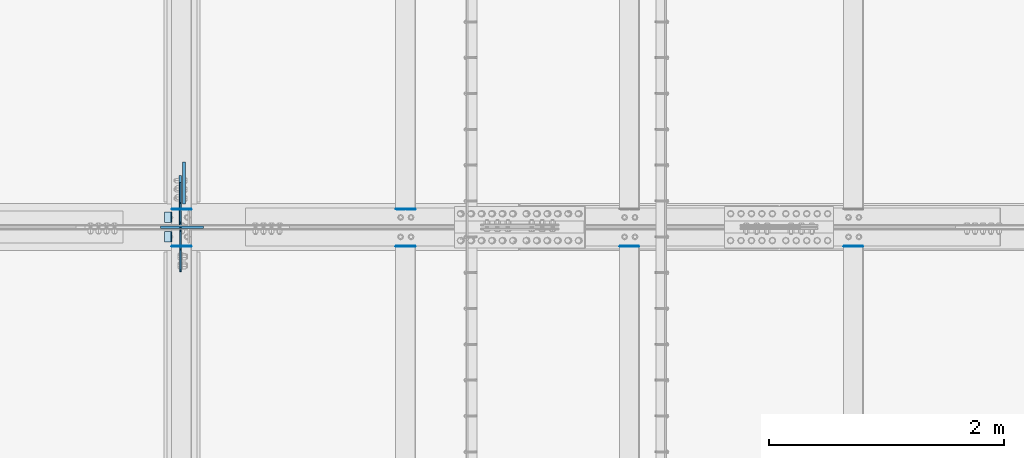
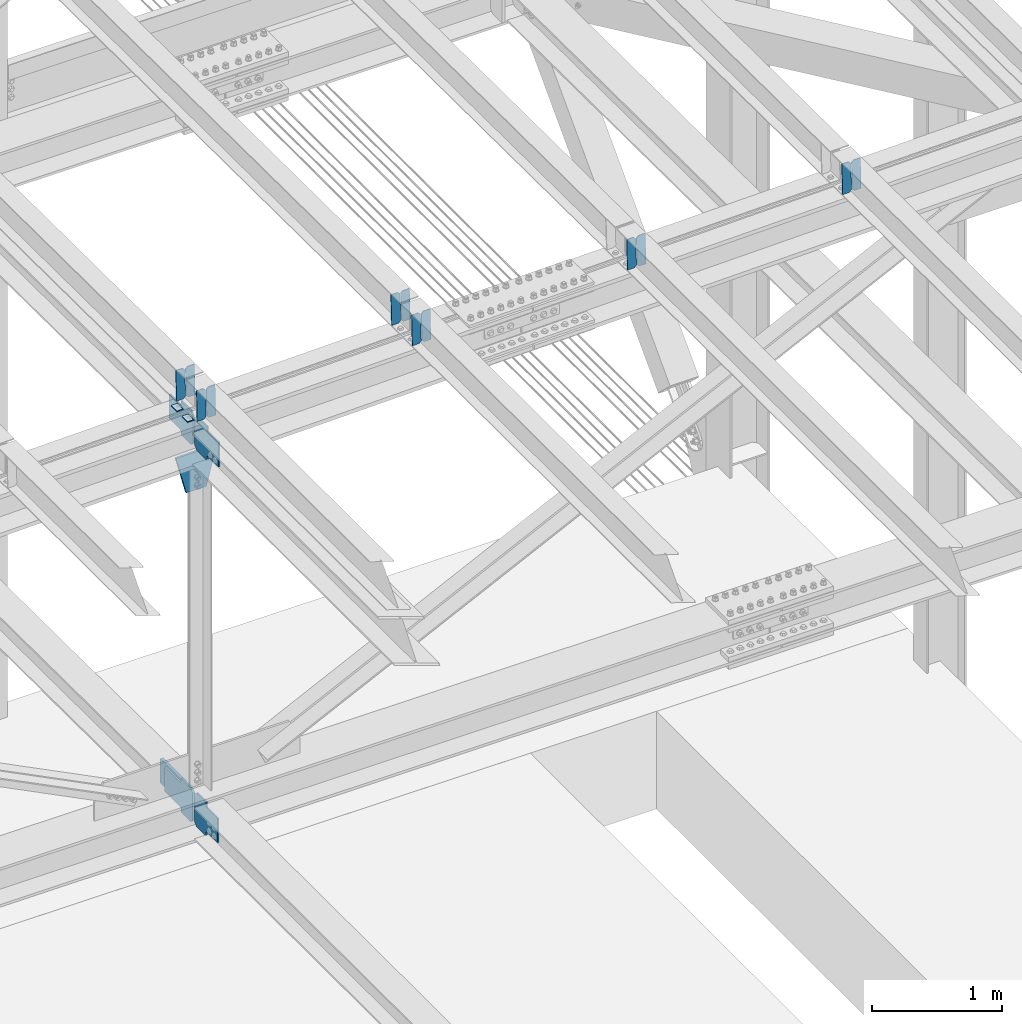
# One storey, part 3448 of 3843: 20 plates, 9 elements without a shape of their own.
"""IFC2X3 building model written with IfcOpenShell, lengths in millimetres."""

from ifc_helpers import new_model, si_unit, frame, origin_with_axes, place, context, subcontext, project, spatial, faceted_brep, material, type_object, element, aggregate, save


model = new_model("IFC2X3")

# Units and contexts
model_context = context("Model", 3, precision=1e-05, world=origin_with_axes())
body_context = subcontext(model_context, "Body", "Model", "MODEL_VIEW")
ifc_project = project(units=[si_unit("LENGTHUNIT", "METRE", prefix="MILLI"), si_unit("AREAUNIT", "SQUARE_METRE"), si_unit("VOLUMEUNIT", "CUBIC_METRE"), si_unit("MASSUNIT", "GRAM", prefix="KILO"), si_unit("TIMEUNIT", "SECOND"), si_unit("PLANEANGLEUNIT", "RADIAN"), si_unit("SOLIDANGLEUNIT", "STERADIAN"), si_unit("THERMODYNAMICTEMPERATUREUNIT", "DEGREE_CELSIUS"), si_unit("LUMINOUSINTENSITYUNIT", "LUMEN")], contexts=[model_context])

# Site, building, storey
site_placement = place(None, origin_with_axes())
site = spatial("IfcSite", under=ifc_project, at=site_placement, CompositionType="ELEMENT")
building_placement = place(site_placement, origin_with_axes())
building = spatial("IfcBuilding", under=site, at=building_placement, Name="Undefined", CompositionType="ELEMENT")
storey_placement = place(building_placement, origin_with_axes())
storey = spatial("IfcBuildingStorey", under=building, at=storey_placement, Name="Undefined", CompositionType="ELEMENT", Elevation=0.0)

# Assembly, plates
assembly_1_placement = place(storey_placement, origin_with_axes())
assembly_1 = element("IfcElementAssembly", 1, at=assembly_1_placement, inside=storey, Name="BEAM", AssemblyPlace="NOTDEFINED", PredefinedType="RIGID_FRAME")
ifc_material = material(Name="STEEL/A572-50")
plate_type_1 = type_object("IfcPlateType", PredefinedType="NOTDEFINED")
plate_1_placement = place(assembly_1_placement, frame((62718.6964783427, 75781.7002512663, 46060.2152839954), z_axis=(-0.0211520980825589, 0.00792817899846704, 0.999744833807344), x_axis=(-0.99977626934565, -0.00016773499999526, -0.021151433007337)))
plate_1 = element("IfcPlate", 2, at=plate_1_placement, type_object=plate_type_1, material=ifc_material, Name="PLATE", context=body_context, shape_type="Brep", body=[
    faceted_brep([(0.0, -3.17499999999927, 0.0), (6.83940015733242e-10, -3.17499999996653, 288.924999998613), (6.54836185276508e-10, 3.17500000001746, 288.924999998591), (0.0, 3.17499999999927, 0.0), (60.3250007643655, -3.17500000017753, 288.924999998606), (60.3250007643219, 3.17499999979918, 288.924999998584), (79.3750000013097, -3.17500000025029, 269.875000761494), (79.375000001266, 3.17499999972642, 269.875000761487), (79.375000000713, -3.17500000026484, 19.0499992370605), (79.3750000006985, 3.17499999971187, 19.0499992370533), (60.325000763667, -3.17500000020664, -1.45519152283669e-11), (60.3250007636234, 3.17499999977736, -3.63797880709171e-11)], [[[0, 1, 2, 3]], [[1, 4, 5, 2]], [[4, 6, 7, 5]], [[6, 8, 9, 7]], [[8, 10, 11, 9]], [[10, 0, 3, 11]], [[5, 7, 9, 11, 3, 2]], [[10, 8, 6, 4, 1, 0]]]),
])
plate_2_placement = place(assembly_1_placement, frame((62632.9906576531, 75781.6858721703, 46058.4020774081), z_axis=(-0.0211520980825589, 0.00792817899846704, 0.999744833807344), x_axis=(-0.99977626934565, -0.00016773499999526, -0.021151433007337)))
plate_2 = element("IfcPlate", 3, at=plate_2_placement, type_object=plate_type_1, material=ifc_material, Name="PLATE", context=body_context, shape_type="Brep", body=[
    faceted_brep([(4.36557456851006e-11, -3.17499999998836, 19.0499992370969), (6.11180439591408e-10, -3.17499999996653, 269.875000761516), (5.96628524363041e-10, 3.17500000001746, 269.875000761502), (1.45519152283669e-11, 3.17499999998836, 19.0499992370824), (19.0499992376572, -3.17500000003201, 288.924999998606), (19.0499992376281, 3.1749999999447, 288.924999998584), (79.3750000013242, -3.17500000025029, 288.924999998591), (79.3750000013097, 3.1749999997337, 288.92499999857), (79.3750000006548, -3.17500000026484, -2.18278728425503e-11), (79.3750000006403, 3.17499999969732, -2.91038304567337e-11), (19.0499992370023, -3.17500000005384, 0.0), (19.0499992369587, 3.17499999992287, -1.45519152283669e-11)], [[[0, 1, 2, 3]], [[1, 4, 5, 2]], [[4, 6, 7, 5]], [[6, 8, 9, 7]], [[8, 10, 11, 9]], [[10, 0, 3, 11]], [[5, 7, 9, 11, 3, 2]], [[10, 8, 6, 4, 1, 0]]]),
])

assembly_2_placement = place(storey_placement, origin_with_axes())
assembly_2 = element("IfcElementAssembly", 4, at=assembly_2_placement, inside=storey, Name="BEAM", AssemblyPlace="NOTDEFINED", PredefinedType="RIGID_FRAME")
plate_3_placement = place(assembly_2_placement, frame((62718.6964783481, 75466.0175545333, 46061.7338311287), z_axis=(-0.0211520980329588, 0.00187065200053622, 0.999774519284172), x_axis=(-0.999776269352655, -3.88860000349027e-05, -0.021152062007432)))
plate_3 = element("IfcPlate", 5, at=plate_3_placement, type_object=plate_type_1, material=ifc_material, Name="PLATE", context=body_context, shape_type="Brep", body=[
    faceted_brep([(0.0, -3.17499999999927, 0.0), (6.83940015733242e-10, -3.17499999996653, 288.924999998613), (6.54836185276508e-10, 3.17500000001746, 288.924999998591), (0.0, 3.17499999999927, 0.0), (60.3250007643655, -3.17500000017753, 288.924999998606), (60.3250007643219, 3.17499999979918, 288.924999998584), (79.3750000013097, -3.17500000025029, 269.875000761494), (79.375000001266, 3.17499999972642, 269.875000761487), (79.375000000713, -3.17500000026484, 19.0499992370605), (79.3750000006985, 3.17499999971187, 19.0499992370533), (60.325000763667, -3.17500000020664, -1.45519152283669e-11), (60.3250007636234, 3.17499999977736, -3.63797880709171e-11)], [[[0, 1, 2, 3]], [[1, 4, 5, 2]], [[4, 6, 7, 5]], [[6, 8, 9, 7]], [[8, 10, 11, 9]], [[10, 0, 3, 11]], [[5, 7, 9, 11, 3, 2]], [[10, 8, 6, 4, 1, 0]]]),
])
plate_4_placement = place(assembly_2_placement, frame((62632.9906576585, 75466.0141617909, 46059.9205707012), z_axis=(-0.0211520980329588, 0.00187065200053622, 0.999774519284172), x_axis=(-0.999776269352655, -3.88860000349027e-05, -0.021152062007432)))
plate_4 = element("IfcPlate", 6, at=plate_4_placement, type_object=plate_type_1, material=ifc_material, Name="PLATE", context=body_context, shape_type="Brep", body=[
    faceted_brep([(4.36557456851006e-11, -3.17499999998836, 19.0499992370969), (6.11180439591408e-10, -3.17499999996653, 269.875000761516), (5.96628524363041e-10, 3.17500000001746, 269.875000761502), (1.45519152283669e-11, 3.17499999998836, 19.0499992370824), (19.0499992376572, -3.17500000003201, 288.924999998606), (19.0499992376281, 3.1749999999447, 288.924999998584), (79.3750000013242, -3.17500000025029, 288.924999998591), (79.3750000013097, 3.1749999997337, 288.92499999857), (79.3750000006548, -3.17500000026484, -2.18278728425503e-11), (79.3750000006403, 3.17499999969732, -2.91038304567337e-11), (19.0499992370023, -3.17500000005384, 0.0), (19.0499992369587, 3.17499999992287, -1.45519152283669e-11)], [[[0, 1, 2, 3]], [[1, 4, 5, 2]], [[4, 6, 7, 5]], [[6, 8, 9, 7]], [[8, 10, 11, 9]], [[10, 0, 3, 11]], [[5, 7, 9, 11, 3, 2]], [[10, 8, 6, 4, 1, 0]]]),
])

assembly_3_placement = place(storey_placement, origin_with_axes())
assembly_3 = element("IfcElementAssembly", 7, at=assembly_3_placement, inside=storey, Name="BEAM", AssemblyPlace="NOTDEFINED", PredefinedType="RIGID_FRAME")
plate_5_placement = place(assembly_3_placement, frame((68433.6967113588, 75465.963914704, 46184.59069618), z_axis=(-0.0211520984965173, 0.00205084399976477, 0.999774165883517), x_axis=(-0.999776269341419, -4.278700010456e-05, -0.0211520550071887)))
plate_5 = element("IfcPlate", 8, at=plate_5_placement, type_object=plate_type_1, material=ifc_material, Name="PLATE", context=body_context, shape_type="Brep", body=[
    faceted_brep([(0.0, -3.17499999999927, 0.0), (6.83940015733242e-10, -3.17499999996653, 288.924999998613), (6.54836185276508e-10, 3.17500000001746, 288.924999998591), (0.0, 3.17499999999927, 0.0), (60.3250007643655, -3.17500000017753, 288.924999998606), (60.3250007643219, 3.17499999979918, 288.924999998584), (79.3750000013097, -3.17500000025029, 269.875000761494), (79.375000001266, 3.17499999972642, 269.875000761487), (79.375000000713, -3.17500000026484, 19.0499992370605), (79.3750000006985, 3.17499999971187, 19.0499992370533), (60.325000763667, -3.17500000020664, -1.45519152283669e-11), (60.3250007636234, 3.17499999977736, -3.63797880709171e-11)], [[[0, 1, 2, 3]], [[1, 4, 5, 2]], [[4, 6, 7, 5]], [[6, 8, 9, 7]], [[8, 10, 11, 9]], [[10, 0, 3, 11]], [[5, 7, 9, 11, 3, 2]], [[10, 8, 6, 4, 1, 0]]]),
])
plate_6_placement = place(assembly_3_placement, frame((68347.9908906676, 75465.9601956653, 46182.7774363933), z_axis=(-0.0211520984965173, 0.00205084399976477, 0.999774165883517), x_axis=(-0.999776269341419, -4.278700010456e-05, -0.0211520550071887)))
plate_6 = element("IfcPlate", 9, at=plate_6_placement, type_object=plate_type_1, material=ifc_material, Name="PLATE", context=body_context, shape_type="Brep", body=[
    faceted_brep([(4.36557456851006e-11, -3.17499999998836, 19.0499992370969), (6.11180439591408e-10, -3.17499999996653, 269.875000761516), (5.96628524363041e-10, 3.17500000001746, 269.875000761502), (1.45519152283669e-11, 3.17499999998836, 19.0499992370824), (19.0499992376572, -3.17500000003201, 288.924999998606), (19.0499992376281, 3.1749999999447, 288.924999998584), (79.3750000013242, -3.17500000025029, 288.924999998591), (79.3750000013097, 3.1749999997337, 288.92499999857), (79.3750000006548, -3.17500000026484, -2.18278728425503e-11), (79.3750000006403, 3.17499999969732, -2.91038304567337e-11), (19.0499992370023, -3.17500000005384, 0.0), (19.0499992369587, 3.17499999992287, -1.45519152283669e-11)], [[[0, 1, 2, 3]], [[1, 4, 5, 2]], [[4, 6, 7, 5]], [[6, 8, 9, 7]], [[8, 10, 11, 9]], [[10, 0, 3, 11]], [[5, 7, 9, 11, 3, 2]], [[10, 8, 6, 4, 1, 0]]]),
])
aggregate(assembly_3, [plate_5, plate_6])

assembly_4_placement = place(storey_placement, origin_with_axes())
assembly_4 = element("IfcElementAssembly", 10, at=assembly_4_placement, inside=storey, Name="BEAM", AssemblyPlace="NOTDEFINED", PredefinedType="RIGID_FRAME")
plate_7_placement = place(assembly_4_placement, frame((66528.6964818659, 75465.9760177746, 46144.1746497953), z_axis=(-0.0211520978066692, 0.00201018800094608, 0.999774248469412), x_axis=(-0.999776269341419, -4.278700010456e-05, -0.0211520550071887)))
plate_7 = element("IfcPlate", 11, at=plate_7_placement, type_object=plate_type_1, material=ifc_material, Name="PLATE", context=body_context, shape_type="Brep", body=[
    faceted_brep([(0.0, -3.17499999999927, 0.0), (6.83940015733242e-10, -3.17499999996653, 288.924999998613), (6.54836185276508e-10, 3.17500000001746, 288.924999998591), (0.0, 3.17499999999927, 0.0), (60.3250007643655, -3.17500000017753, 288.924999998606), (60.3250007643219, 3.17499999979918, 288.924999998584), (79.3750000013097, -3.17500000025029, 269.875000761494), (79.375000001266, 3.17499999972642, 269.875000761487), (79.375000000713, -3.17500000026484, 19.0499992370605), (79.3750000006985, 3.17499999971187, 19.0499992370533), (60.325000763667, -3.17500000020664, -1.45519152283669e-11), (60.3250007636234, 3.17499999977736, -3.63797880709171e-11)], [[[0, 1, 2, 3]], [[1, 4, 5, 2]], [[4, 6, 7, 5]], [[6, 8, 9, 7]], [[8, 10, 11, 9]], [[10, 0, 3, 11]], [[5, 7, 9, 11, 3, 2]], [[10, 8, 6, 4, 1, 0]]]),
])
plate_8_placement = place(assembly_4_placement, frame((66442.9906611746, 75465.9723700711, 46142.3613898619), z_axis=(-0.0211520978066692, 0.00201018800094608, 0.999774248469412), x_axis=(-0.999776269341419, -4.278700010456e-05, -0.0211520550071887)))
plate_8 = element("IfcPlate", 12, at=plate_8_placement, type_object=plate_type_1, material=ifc_material, Name="PLATE", context=body_context, shape_type="Brep", body=[
    faceted_brep([(4.36557456851006e-11, -3.17499999998836, 19.0499992370969), (6.11180439591408e-10, -3.17499999996653, 269.875000761516), (5.96628524363041e-10, 3.17500000001746, 269.875000761502), (1.45519152283669e-11, 3.17499999998836, 19.0499992370824), (19.0499992376572, -3.17500000003201, 288.924999998606), (19.0499992376281, 3.1749999999447, 288.924999998584), (79.3750000013242, -3.17500000025029, 288.924999998591), (79.3750000013097, 3.1749999997337, 288.92499999857), (79.3750000006548, -3.17500000026484, -2.18278728425503e-11), (79.3750000006403, 3.17499999969732, -2.91038304567337e-11), (19.0499992370023, -3.17500000005384, 0.0), (19.0499992369587, 3.17499999992287, -1.45519152283669e-11)], [[[0, 1, 2, 3]], [[1, 4, 5, 2]], [[4, 6, 7, 5]], [[6, 8, 9, 7]], [[8, 10, 11, 9]], [[10, 0, 3, 11]], [[5, 7, 9, 11, 3, 2]], [[10, 8, 6, 4, 1, 0]]]),
])
aggregate(assembly_4, [plate_7, plate_8])

assembly_5_placement = place(storey_placement, origin_with_axes())
assembly_5 = element("IfcElementAssembly", 13, at=assembly_5_placement, inside=storey, Name="BEAM", AssemblyPlace="NOTDEFINED", PredefinedType="RIGID_FRAME")
plate_9_placement = place(assembly_5_placement, frame((64623.6967069092, 75781.6879853969, 46101.7727157053), z_axis=(-0.0211520981591165, 0.00796893299830843, 0.999744509787543), x_axis=(-0.99977626934565, -0.00016773499999526, -0.021151433007337)))
plate_9 = element("IfcPlate", 14, at=plate_9_placement, type_object=plate_type_1, material=ifc_material, Name="PLATE", context=body_context, shape_type="Brep", body=[
    faceted_brep([(0.0, -3.17499999999927, 0.0), (6.83940015733242e-10, -3.17499999996653, 288.924999998613), (6.54836185276508e-10, 3.17500000001746, 288.924999998591), (0.0, 3.17499999999927, 0.0), (60.3250007643655, -3.17500000017753, 288.924999998606), (60.3250007643219, 3.17499999979918, 288.924999998584), (79.3750000013097, -3.17500000025029, 269.875000761494), (79.375000001266, 3.17499999972642, 269.875000761487), (79.375000000713, -3.17500000026484, 19.0499992370605), (79.3750000006985, 3.17499999971187, 19.0499992370533), (60.325000763667, -3.17500000020664, -1.45519152283669e-11), (60.3250007636234, 3.17499999977736, -3.63797880709171e-11)], [[[0, 1, 2, 3]], [[1, 4, 5, 2]], [[4, 6, 7, 5]], [[6, 8, 9, 7]], [[8, 10, 11, 9]], [[10, 0, 3, 11]], [[5, 7, 9, 11, 3, 2]], [[10, 8, 6, 4, 1, 0]]]),
])
plate_10_placement = place(assembly_5_placement, frame((64537.9908862199, 75781.6735299861, 46099.9595097248), z_axis=(-0.0211520981591165, 0.00796893299830843, 0.999744509787543), x_axis=(-0.99977626934565, -0.00016773499999526, -0.021151433007337)))
plate_10 = element("IfcPlate", 15, at=plate_10_placement, type_object=plate_type_1, material=ifc_material, Name="PLATE", context=body_context, shape_type="Brep", body=[
    faceted_brep([(4.36557456851006e-11, -3.17499999998836, 19.0499992370969), (6.11180439591408e-10, -3.17499999996653, 269.875000761516), (5.96628524363041e-10, 3.17500000001746, 269.875000761502), (1.45519152283669e-11, 3.17499999998836, 19.0499992370824), (19.0499992376572, -3.17500000003201, 288.924999998606), (19.0499992376281, 3.1749999999447, 288.924999998584), (79.3750000013242, -3.17500000025029, 288.924999998591), (79.3750000013097, 3.1749999997337, 288.92499999857), (79.3750000006548, -3.17500000026484, -2.18278728425503e-11), (79.3750000006403, 3.17499999969732, -2.91038304567337e-11), (19.0499992370023, -3.17500000005384, 0.0), (19.0499992369587, 3.17499999992287, -1.45519152283669e-11)], [[[0, 1, 2, 3]], [[1, 4, 5, 2]], [[4, 6, 7, 5]], [[6, 8, 9, 7]], [[8, 10, 11, 9]], [[10, 0, 3, 11]], [[5, 7, 9, 11, 3, 2]], [[10, 8, 6, 4, 1, 0]]]),
])
aggregate(assembly_5, [plate_9, plate_10])

assembly_6_placement = place(storey_placement, origin_with_axes())
assembly_6 = element("IfcElementAssembly", 16, at=assembly_6_placement, inside=storey, Name="BEAM", AssemblyPlace="NOTDEFINED", PredefinedType="RIGID_FRAME")
plate_11_placement = place(assembly_6_placement, frame((64623.6967112793, 75465.99690233, 46103.3087150513), z_axis=(-0.0211520978190965, 0.00194001800016849, 0.999774387093413), x_axis=(-0.999776269338344, -4.08370000134752e-05, -0.0211520590071558)))
plate_11 = element("IfcPlate", 17, at=plate_11_placement, type_object=plate_type_1, material=ifc_material, Name="PLATE", context=body_context, shape_type="Brep", body=[
    faceted_brep([(0.0, -3.17499999999927, 0.0), (6.83940015733242e-10, -3.17499999996653, 288.924999998613), (6.54836185276508e-10, 3.17500000001746, 288.924999998591), (0.0, 3.17499999999927, 0.0), (60.3250007643655, -3.17500000017753, 288.924999998606), (60.3250007643219, 3.17499999979918, 288.924999998584), (79.3750000013097, -3.17500000025029, 269.875000761494), (79.375000001266, 3.17499999972642, 269.875000761487), (79.375000000713, -3.17500000026484, 19.0499992370605), (79.3750000006985, 3.17499999971187, 19.0499992370533), (60.325000763667, -3.17500000020664, -1.45519152283669e-11), (60.3250007636234, 3.17499999977736, -3.63797880709171e-11)], [[[0, 1, 2, 3]], [[1, 4, 5, 2]], [[4, 6, 7, 5]], [[6, 8, 9, 7]], [[8, 10, 11, 9]], [[10, 0, 3, 11]], [[5, 7, 9, 11, 3, 2]], [[10, 8, 6, 4, 1, 0]]]),
])
plate_12_placement = place(assembly_6_placement, frame((64537.9908905899, 75465.9933842938, 46101.4954548632), z_axis=(-0.0211520978190965, 0.00194001800016849, 0.999774387093413), x_axis=(-0.999776269338344, -4.08370000134752e-05, -0.0211520590071558)))
plate_12 = element("IfcPlate", 18, at=plate_12_placement, type_object=plate_type_1, material=ifc_material, Name="PLATE", context=body_context, shape_type="Brep", body=[
    faceted_brep([(4.36557456851006e-11, -3.17499999998836, 19.0499992370969), (6.11180439591408e-10, -3.17499999996653, 269.875000761516), (5.96628524363041e-10, 3.17500000001746, 269.875000761502), (1.45519152283669e-11, 3.17499999998836, 19.0499992370824), (19.0499992376572, -3.17500000003201, 288.924999998606), (19.0499992376281, 3.1749999999447, 288.924999998584), (79.3750000013242, -3.17500000025029, 288.924999998591), (79.3750000013097, 3.1749999997337, 288.92499999857), (79.3750000006548, -3.17500000026484, -2.18278728425503e-11), (79.3750000006403, 3.17499999969732, -2.91038304567337e-11), (19.0499992370023, -3.17500000005384, 0.0), (19.0499992369587, 3.17499999992287, -1.45519152283669e-11)], [[[0, 1, 2, 3]], [[1, 4, 5, 2]], [[4, 6, 7, 5]], [[6, 8, 9, 7]], [[8, 10, 11, 9]], [[10, 0, 3, 11]], [[5, 7, 9, 11, 3, 2]], [[10, 8, 6, 4, 1, 0]]]),
])
aggregate(assembly_6, [plate_11, plate_12])

# Plate
plate_type_2 = type_object("IfcPlateType", PredefinedType="NOTDEFINED")
plate_13_placement = place(assembly_1_placement, frame((62553.7676306388, 75755.5, 46051.5939415684), z_axis=(0.0, -1.0, 0.0), x_axis=(-0.999776270257024, 0.0, -0.0211520550054595)))
plate_13 = element("IfcPlate", 19, at=plate_13_placement, type_object=plate_type_2, material=ifc_material, Name="PLATE", context=body_context, shape_type="Brep", body=[
    faceted_brep([(9.52499999982683, -4.7625000001135, 88.8999999999942), (0.0, 4.76249999999709, 88.9000015258789), (0.0, 4.76249999999709, 0.0), (9.52499999981956, -4.76249999999709, 0.0), (63.4999984608512, -4.76249999988795, 88.8999999999796), (63.4999984608367, -4.76249999988795, -1.45519152283669e-11), (63.4999984608221, 4.76250000013533, -1.45519152283669e-11), (63.4999984608367, 4.76250000013533, 88.8999999999796)], [[[0, 1, 2, 3]], [[4, 5, 6, 7]], [[5, 4, 0, 3]], [[6, 5, 3, 2]], [[7, 6, 2, 1]], [[4, 7, 1, 0]]]),
])

aggregate(assembly_1, [plate_1, plate_2, plate_13])

plate_14_placement = place(assembly_2_placement, frame((62553.7676306388, 75590.4000015258, 46051.5939415684), z_axis=(0.0, -1.0, 0.0), x_axis=(-0.999776270257024, 0.0, -0.0211520550054595)))
plate_14 = element("IfcPlate", 20, at=plate_14_placement, type_object=plate_type_2, material=ifc_material, Name="PLATE", context=body_context, shape_type="Brep", body=[
    faceted_brep([(9.52499999982683, -4.7625000001135, 88.8999999999942), (0.0, 4.76249999999709, 88.9000015258789), (0.0, 4.76249999999709, 0.0), (9.52499999981956, -4.76249999999709, 0.0), (63.4999984608512, -4.76249999988795, 88.8999999999796), (63.4999984608367, -4.76249999988795, -1.45519152283669e-11), (63.4999984608221, 4.76250000013533, -1.45519152283669e-11), (63.4999984608367, 4.76250000013533, 88.8999999999796)], [[[0, 1, 2, 3]], [[4, 5, 6, 7]], [[5, 4, 0, 3]], [[6, 5, 3, 2]], [[7, 6, 2, 1]], [[4, 7, 1, 0]]]),
])

aggregate(assembly_2, [plate_3, plate_4, plate_14])

# Assembly, plate
assembly_7_placement = place(storey_placement, origin_with_axes())
assembly_7 = element("IfcElementAssembly", 21, at=assembly_7_placement, inside=storey, Name="BEAM", AssemblyPlace="NOTDEFINED", PredefinedType="RIGID_FRAME")
plate_type_3 = type_object("IfcPlateType", PredefinedType="NOTDEFINED")
plate_15_placement = place(assembly_7_placement, frame((62625.2874999051, 75621.3562499733, 42198.3670469889), z_axis=(0.0, -0.707106781186682, 0.707106781186413), x_axis=(0.0, -0.707106781186548, -0.707106781186548)))
plate_15 = element("IfcPlate", 22, at=plate_15_placement, type_object=plate_type_3, material=ifc_material, Name="PLATE", context=body_context, shape_type="Brep", body=[
    faceted_brep([(0.0, -6.3499999046162, 0.0), (-179.597849441064, -6.34999999999854, 179.597849441059), (-179.597849441064, 6.34999999999854, 179.597849441059), (7.27595761418343e-12, 6.3499999046162, 0.0), (-179.597849441061, -6.34999999999854, 224.499130046192), (-179.597849441061, 6.34999999999854, 224.499130046192), (-75.7636380416931, -6.34999999999854, 328.333341445563), (-75.7636380416931, 6.34999999999854, 328.333341445563), (-53.6447545305273, -6.34999999999854, 306.214457898401), (-53.6447545305273, 6.34999999999854, 306.214457898401), (-49.5245780623809, -6.34999999999854, 303.461443997949), (-49.5245780623809, 6.34999999999854, 303.461443997949), (-44.6644985443563, -6.34999999999854, 302.494714075376), (-44.6644985443563, 6.34999999999854, 302.494714075376), (-39.8044190263026, -6.34999999999854, 303.461443997981), (-39.8044190263026, 6.34999999999854, 303.461443997981), (-35.6842425581272, -6.34999999999854, 306.214457898459), (-35.6842425581272, 6.34999999999854, 306.214457898459), (81.0590871709428, -6.34999999999854, 422.957787626525), (81.0590871709428, 6.34999999999854, 422.957787626525), (242.703697350371, -6.34999999999854, 261.313177447377), (242.703697350371, 6.34999999999854, 261.313177447377), (125.960367621417, -6.34999999999854, 144.569847719406), (125.960367621417, 6.34999999999854, 144.569847719406), (123.207353720878, -6.34999999999854, 140.449671251223), (123.207353720878, 6.34999999999854, 140.449671251223), (122.24062379825, -6.34999999999854, 135.58959173314), (122.24062379825, 6.34999999999854, 135.58959173314), (123.20735372082, -6.34999999999854, 130.729512215075), (123.20735372082, 6.34999999999854, 130.729512215075), (125.960367621301, -6.34999999999854, 126.609335746911), (125.960367621301, 6.34999999999854, 126.609335746911), (148.735492004496, -6.35000000000582, 103.834211399357), (148.735492004496, 6.35000000000582, 103.834211399357), (44.9012806051323, -6.35000000000582, -1.45519152283669e-11), (44.9012806051323, 6.35000000000582, -1.45519152283669e-11)], [[[0, 1, 2, 3]], [[1, 4, 5, 2]], [[4, 6, 7, 5]], [[6, 8, 9, 7]], [[8, 10, 11, 9]], [[10, 12, 13, 11]], [[12, 14, 15, 13]], [[14, 16, 17, 15]], [[16, 18, 19, 17]], [[18, 20, 21, 19]], [[20, 22, 23, 21]], [[22, 24, 25, 23]], [[24, 26, 27, 25]], [[26, 28, 29, 27]], [[28, 30, 31, 29]], [[30, 32, 33, 31]], [[32, 34, 35, 33]], [[34, 0, 3, 35]], [[5, 7, 9, 11, 13, 15, 17, 19, 21, 23, 25, 27, 29, 31, 33, 35, 3, 2]], [[34, 32, 30, 28, 26, 24, 22, 20, 18, 16, 14, 12, 10, 8, 6, 4, 1, 0]]]),
])

# Assembly, plates
assembly_8_placement = place(storey_placement, origin_with_axes())
assembly_8 = element("IfcElementAssembly", 23, at=assembly_8_placement, inside=storey, Name="BEAM", AssemblyPlace="NOTDEFINED", PredefinedType="RIGID_FRAME")
plate_16_placement = place(assembly_8_placement, frame((62625.2874998879, 75617.3875000357, 45724.5309675924), z_axis=(0.0, -0.707106781186682, 0.707106781186413), x_axis=(0.0, -0.707106781186548, -0.707106781186548)))
plate_16 = element("IfcPlate", 24, at=plate_16_placement, type_object=plate_type_3, material=ifc_material, Name="PLATE", context=body_context, shape_type="Brep", body=[
    faceted_brep([(0.0, -6.3499999046162, 0.0), (-179.463032808948, -6.34999999999854, 179.463032808635), (-179.463032808948, 6.34999999999854, 179.463032808635), (7.27595761418343e-12, 6.3499999046162, 0.0), (-179.463032808992, -6.34999999999854, 224.364313413753), (-179.463032808992, 6.34999999999854, 224.364313413753), (-68.332363235801, -6.34999999999854, 335.494982985998), (-68.332363235801, 6.34999999999854, 335.494982985998), (-46.4665045499755, -6.34999999999854, 313.629124300205), (-46.4665045499755, 6.34999999999854, 313.629124300205), (-42.3463280818473, -6.34999999999854, 310.876110399739), (-42.3463280818473, 6.34999999999854, 310.876110399739), (-37.48624856383, -6.34999999999854, 309.909380477155), (-37.48624856383, 6.34999999999854, 309.909380477155), (-32.6261690458091, -6.34999999999854, 310.876110399731), (-32.6261690458091, 6.34999999999854, 310.876110399731), (-28.5059925776736, -6.34999999999854, 313.629124300176), (-28.5059925776736, 6.34999999999854, 313.629124300176), (88.2373370560413, -6.34999999999854, 430.372453932898), (88.2373370560413, 6.34999999999854, 430.372453932898), (249.88194723548, -6.34999999999854, 268.727843753732), (249.88194723548, 6.34999999999854, 268.727843753732), (133.138617601856, -6.34999999999854, 151.984514121097), (133.138617601856, 6.34999999999854, 151.984514121097), (130.385603701357, -6.34999999999854, 147.864337652951), (130.385603701357, 6.34999999999854, 147.864337652951), (129.418873778762, -6.34999999999854, 143.004258134912), (129.418873778762, 6.34999999999854, 143.004258134912), (130.385603701342, -6.34999999999854, 138.144178616851), (130.385603701342, 6.34999999999854, 138.144178616851), (133.138617601831, -6.34999999999854, 134.024002148697), (133.138617601831, 6.34999999999854, 134.024002148697), (156.031950102829, -6.35000000000582, 111.130669497703), (156.031950102829, 6.35000000000582, 111.130669497703), (44.9012806051323, -6.35000000000582, -1.45519152283669e-11), (44.9012806051323, 6.35000000000582, -1.45519152283669e-11)], [[[0, 1, 2, 3]], [[1, 4, 5, 2]], [[4, 6, 7, 5]], [[6, 8, 9, 7]], [[8, 10, 11, 9]], [[10, 12, 13, 11]], [[12, 14, 15, 13]], [[14, 16, 17, 15]], [[16, 18, 19, 17]], [[18, 20, 21, 19]], [[20, 22, 23, 21]], [[22, 24, 25, 23]], [[24, 26, 27, 25]], [[26, 28, 29, 27]], [[28, 30, 31, 29]], [[30, 32, 33, 31]], [[32, 34, 35, 33]], [[34, 0, 3, 35]], [[5, 7, 9, 11, 13, 15, 17, 19, 21, 23, 25, 27, 29, 31, 33, 35, 3, 2]], [[34, 32, 30, 28, 26, 24, 22, 20, 18, 16, 14, 12, 10, 8, 6, 4, 1, 0]]]),
])
plate_17_placement = place(assembly_8_placement, frame((62625.2874997662, 75639.6125, 45724.5309665206), z_axis=(0.0, 0.707106781186548, 0.707106781186548), x_axis=(5.70000238222118e-08, 0.707106781186546, -0.707106781186546)))
plate_17 = element("IfcPlate", 25, at=plate_17_placement, type_object=plate_type_3, material=ifc_material, Name="PLATE", context=body_context, shape_type="Brep", body=[
    faceted_brep([(0.0, -6.3499999046162, 0.0), (-179.463032808948, -6.34999999999854, 179.463032808635), (-179.463032808948, 6.34999999999854, 179.463032808635), (7.27595761418343e-12, 6.3499999046162, 0.0), (-179.463032808992, -6.34999999999854, 224.364313413753), (-179.463032808992, 6.34999999999854, 224.364313413753), (-68.332363235801, -6.34999999999854, 335.494982985998), (-68.332363235801, 6.34999999999854, 335.494982985998), (-44.6841798851528, -6.34999999999854, 311.846799503114), (-44.6841798851528, 6.34999999999854, 311.846799503114), (-40.564003417021, -6.34999999999854, 309.09378560264), (-40.564003417021, 6.34999999999854, 309.09378560264), (-35.7039238989819, -6.34999999999854, 308.127055680056), (-35.7039238989819, 6.34999999999854, 308.127055680056), (-30.8438443809428, -6.34999999999854, 309.093785602647), (-30.8438443809428, 6.34999999999854, 309.093785602647), (-26.7236679127964, -6.34999999999854, 311.846799503114), (-26.7236679127964, 6.34999999999854, 311.846799503114), (90.0196617893234, -6.34999999999854, 428.590129205244), (90.0196617893234, 6.34999999999854, 428.590129205244), (251.664271967791, -6.34999999999854, 266.945519026769), (251.664271967791, 6.34999999999854, 266.945519026769), (134.920942265657, -6.34999999999854, 150.202189324639), (134.920942265657, 6.34999999999854, 150.202189324639), (132.167928365197, -6.34999999999854, 146.082012856496), (132.167928365197, 6.34999999999854, 146.082012856496), (131.201198442606, -6.34999999999854, 141.221933338468), (131.201198442606, 6.34999999999854, 141.221933338468), (132.16792836519, -6.34999999999854, 136.361853820429), (132.16792836519, 6.34999999999854, 136.361853820429), (134.920942265671, -6.34999999999854, 132.24167735229), (134.920942265671, 6.34999999999854, 132.24167735229), (156.031950102829, -6.35000000000582, 111.130669497703), (156.031950102829, 6.35000000000582, 111.130669497703), (44.9012806051323, -6.35000000000582, -1.45519152283669e-11), (44.9012806051323, 6.35000000000582, -1.45519152283669e-11)], [[[0, 1, 2, 3]], [[1, 4, 5, 2]], [[4, 6, 7, 5]], [[6, 8, 9, 7]], [[8, 10, 11, 9]], [[10, 12, 13, 11]], [[12, 14, 15, 13]], [[14, 16, 17, 15]], [[16, 18, 19, 17]], [[18, 20, 21, 19]], [[20, 22, 23, 21]], [[22, 24, 25, 23]], [[24, 26, 27, 25]], [[26, 28, 29, 27]], [[28, 30, 31, 29]], [[30, 32, 33, 31]], [[32, 34, 35, 33]], [[34, 0, 3, 35]], [[5, 7, 9, 11, 13, 15, 17, 19, 21, 23, 25, 27, 29, 31, 33, 35, 3, 2]], [[34, 32, 30, 28, 26, 24, 22, 20, 18, 16, 14, 12, 10, 8, 6, 4, 1, 0]]]),
])

# Plate
plate_type_4 = type_object("IfcPlateType", PredefinedType="NOTDEFINED")
plate_18_placement = place(assembly_7_placement, frame((62622.1124996538, 75635.64375, 42198.3669081537), z_axis=(0.0, 0.707106781186548, 0.707106781186548), x_axis=(5.70000238222118e-08, 0.707106781186546, -0.707106781186546)))
plate_18 = element("IfcPlate", 26, at=plate_18_placement, type_object=plate_type_4, material=ifc_material, Name="PLATE", context=body_context, shape_type="Brep", body=[
    faceted_brep([(0.0, -9.52500000000146, 0.0), (-179.594171692268, -9.52500000000146, 179.594171692269), (-179.594171692268, 9.52500000000146, 179.594171692269), (0.0, 9.52500000000146, 0.0), (-179.594171692268, -9.52500000000146, 224.495452297391), (-179.594171692268, 9.52500000000146, 224.495452297391), (-75.7599603253911, -9.52500000000146, 328.329663664257), (-75.7599603253911, 9.52500000000146, 328.329663664257), (-51.9621452996544, -9.52500000000146, 304.531848708706), (-51.9621452996544, 9.52500000000146, 304.531848708706), (-47.8419688314934, -9.52500000000146, 301.778834808239), (-47.8419688314934, 9.52500000000146, 301.778834808239), (-42.9818893134543, -9.52500000000146, 300.81210488567), (-42.9818893134543, 9.52500000000146, 300.81210488567), (-38.1218097953788, -9.52500000000146, 301.778834808298), (-38.1218097953788, 9.52500000000146, 301.778834808298), (-34.0016333272033, -9.52500000000146, 304.531848708808), (-34.0016333272033, 9.52500000000146, 304.531848708808), (136.623233110735, -9.52500000000146, 475.156715146732), (136.623233110735, 9.52500000000146, 475.156715146732), (298.267843289195, -9.52500000000146, 313.512104968264), (298.267843289195, 9.52500000000146, 313.512104968264), (127.642976851261, -9.52500000000146, 142.88723853034), (127.642976851261, 9.52500000000146, 142.88723853034), (124.88996295075, -9.52500000000146, 138.767062062165), (124.88996295075, 9.52500000000146, 138.767062062165), (123.92323302813, -9.52500000000146, 133.906982544082), (123.92323302813, 9.52500000000146, 133.906982544082), (124.889962950707, -9.52500000000146, 129.046903026043), (124.889962950707, 9.52500000000146, 129.046903026043), (127.642976851166, -9.52500000000146, 124.926726557882), (127.642976851166, 9.52500000000146, 124.926726557882), (148.735492003645, -9.52499999999418, 103.834211398527), (148.735492003645, 9.52499999999418, 103.834211398527), (44.9012806055835, -9.52499999999418, 4.65661287307739e-10), (44.9012806055835, 9.52499999999418, 4.65661287307739e-10)], [[[0, 1, 2, 3]], [[1, 4, 5, 2]], [[4, 6, 7, 5]], [[6, 8, 9, 7]], [[8, 10, 11, 9]], [[10, 12, 13, 11]], [[12, 14, 15, 13]], [[14, 16, 17, 15]], [[16, 18, 19, 17]], [[18, 20, 21, 19]], [[20, 22, 23, 21]], [[22, 24, 25, 23]], [[24, 26, 27, 25]], [[26, 28, 29, 27]], [[28, 30, 31, 29]], [[30, 32, 33, 31]], [[32, 34, 35, 33]], [[34, 0, 3, 35]], [[5, 7, 9, 11, 13, 15, 17, 19, 21, 23, 25, 27, 29, 31, 33, 35, 3, 2]], [[34, 32, 30, 28, 26, 24, 22, 20, 18, 16, 14, 12, 10, 8, 6, 4, 1, 0]]]),
])

aggregate(assembly_7, [plate_15, plate_18])

# Assembly, plate
assembly_9_placement = place(storey_placement, origin_with_axes())
assembly_9 = element("IfcElementAssembly", 27, at=assembly_9_placement, inside=storey, Name="BEAM", AssemblyPlace="NOTDEFINED", PredefinedType="RIGID_FRAME")
plate_type_5 = type_object("IfcPlateType", PredefinedType="NOTDEFINED")
plate_19_placement = place(assembly_9_placement, frame((62653.8625000005, 75826.9374998122, 42437.74622896), z_axis=(0.0, 0.0, -1.0), x_axis=(0.0, 1.0, 0.0)))
plate_19 = element("IfcPlate", 28, at=plate_19_placement, type_object=plate_type_5, material=ifc_material, Name="PLATE", context=body_context, shape_type="Brep", body=[
    faceted_brep([(0.0, -12.6999999999971, 0.0), (1.30967237055302e-10, -12.6999999999971, 228.600000023711), (1.30967237055302e-10, 12.6999999999971, 228.600000023711), (0.0, 12.6999999999971, 0.0), (355.600000000137, -12.6999999999971, 228.600000023711), (355.600000000137, 12.6999999999971, 228.600000023711), (355.599999999999, -12.7000000000007, 0.0), (355.599999999999, 12.7000000000007, 0.0)], [[[0, 1, 2, 3]], [[1, 4, 5, 2]], [[4, 6, 7, 5]], [[6, 0, 3, 7]], [[5, 7, 3, 2]], [[6, 4, 1, 0]]]),
])
aggregate(assembly_9, [plate_19])

# Plate
plate_type_6 = type_object("IfcPlateType", PredefinedType="NOTDEFINED")
plate_20_placement = place(assembly_8_placement, frame((62819.2655575553, 75628.5, 45658.4038211784), z_axis=(0.0219709250020387, 0.0, -0.999758610092734), x_axis=(-0.999758610092734, 0.0, -0.0219709250020408)))
plate_20 = element("IfcPlate", 29, at=plate_20_placement, type_object=plate_type_6, material=ifc_material, Name="PLATE", context=body_context, shape_type="Brep", body=[
    faceted_brep([(0.0, -9.52500000000146, 0.0), (101.883525964819, -9.52499999999418, 359.265553268546), (101.883525964819, 9.52499999999418, 359.265553268546), (0.0, 9.52500000000146, 0.0), (279.640607086476, -9.52499999999418, 355.359133510377), (279.640607086476, 9.52499999999418, 355.359133510377), (364.111441374291, -9.52499999999418, 7.42147676646709e-10), (364.111441374291, 9.52499999999418, 7.42147676646709e-10)], [[[0, 1, 2, 3]], [[1, 4, 5, 2]], [[4, 6, 7, 5]], [[6, 0, 3, 7]], [[5, 7, 3, 2]], [[6, 4, 1, 0]]]),
])

aggregate(assembly_8, [plate_16, plate_17, plate_20])

save(model, "model.ifc")
